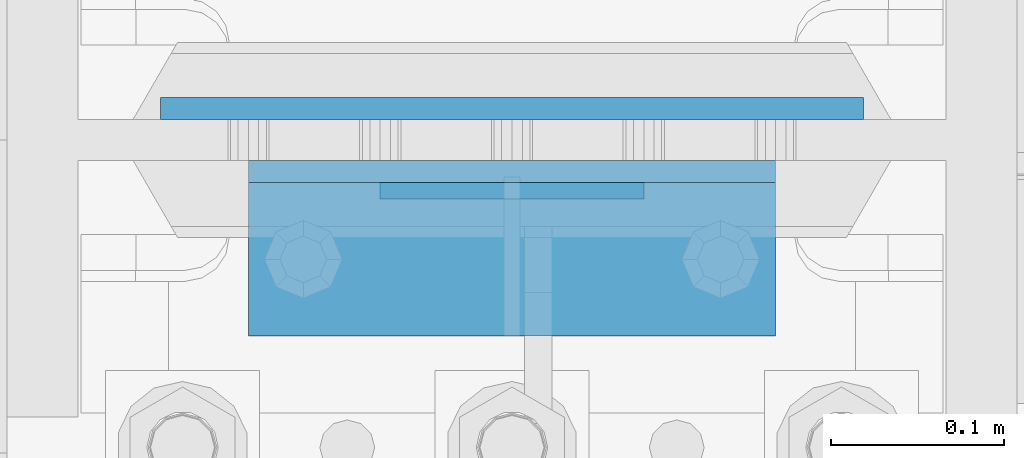
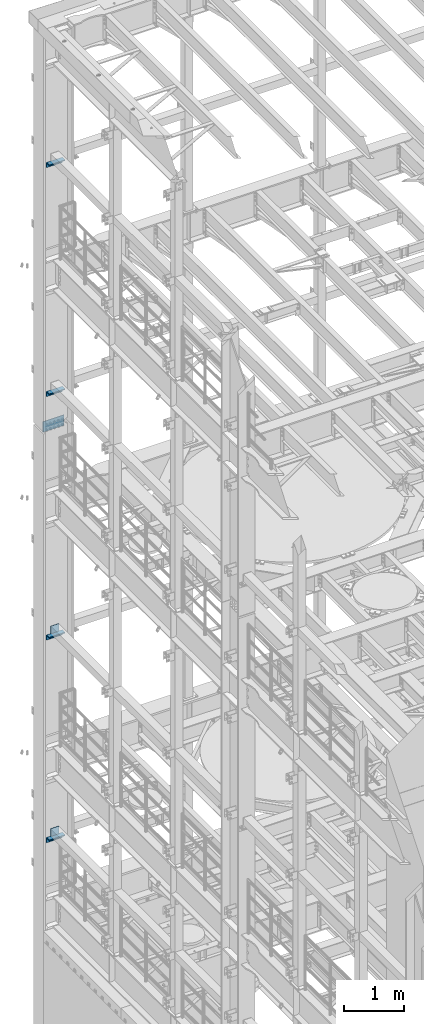
# One storey, part 1317 of 1876: 11 beams, 6 elements without a shape of their own.
"""IFC2X3 building model written with IfcOpenShell, lengths in millimetres."""

from ifc_helpers import new_model, si_unit, frame, origin_with_axes, place, context, subcontext, project, spatial, faceted_brep, material, type_object, element, aggregate, save


model = new_model("IFC2X3")

# Units and contexts
model_context = context("Model", 3, precision=1e-05, world=origin_with_axes())
body_context = subcontext(model_context, "Body", "Model", "MODEL_VIEW")
ifc_project = project(units=[si_unit("LENGTHUNIT", "METRE", prefix="MILLI"), si_unit("AREAUNIT", "SQUARE_METRE"), si_unit("VOLUMEUNIT", "CUBIC_METRE"), si_unit("MASSUNIT", "GRAM", prefix="KILO"), si_unit("TIMEUNIT", "SECOND"), si_unit("PLANEANGLEUNIT", "RADIAN"), si_unit("SOLIDANGLEUNIT", "STERADIAN"), si_unit("THERMODYNAMICTEMPERATUREUNIT", "DEGREE_CELSIUS"), si_unit("LUMINOUSINTENSITYUNIT", "LUMEN")], contexts=[model_context])

# Site, building, storey
site_placement = place(None, origin_with_axes())
site = spatial("IfcSite", under=ifc_project, at=site_placement, CompositionType="ELEMENT")
building_placement = place(site_placement, origin_with_axes())
building = spatial("IfcBuilding", under=site, at=building_placement, Name="Undefined", CompositionType="ELEMENT")
storey_placement = place(building_placement, origin_with_axes())
storey = spatial("IfcBuildingStorey", under=building, at=storey_placement, Name="Undefined", CompositionType="ELEMENT", Elevation=0.0)

# Assembly, beam
assembly_1_placement = place(storey_placement, origin_with_axes())
assembly_1 = element("IfcElementAssembly", 1, at=assembly_1_placement, inside=storey, Name="BEAM", AssemblyPlace="NOTDEFINED", PredefinedType="RIGID_FRAME")
ifc_material_1 = material(Name="STEEL/A36")
beam_type_1 = type_object("IfcBeamType", PredefinedType="NOTDEFINED")
beam_1_placement = place(assembly_1_placement, frame((76.1999999999998, 13686.63125, 10420.35), z_axis=(0.0, 0.0, -1.0), x_axis=(-1.0, 0.0, 0.0)))
beam_1 = element("IfcBeam", 2, at=beam_1_placement, type_object=beam_type_1, material=ifc_material_1, Name="PLATE", context=body_context, shape_type="Brep", body=[
    faceted_brep([(0.0, 4.76249999999982, -76.1999999999998), (3.63797880709171e-12, 4.76249999999982, 76.1999969482422), (152.399993896484, 4.76250000000073, 76.1999969482422), (152.4, 4.76249999999982, -76.1999999999998), (3.63797880709171e-12, -4.76249999999982, 76.1999969482422), (152.399993896484, -4.76250000000073, 76.1999969482422), (0.0, -4.76249999999982, -76.1999999999998), (152.4, -4.76249999999982, -76.1999999999998)], [[[0, 1, 2, 3]], [[4, 5, 2, 1]], [[4, 6, 7, 5]], [[6, 0, 3, 7]], [[5, 7, 3, 2]], [[6, 4, 1, 0]]]),
])

assembly_2_placement = place(storey_placement, origin_with_axes())
assembly_2 = element("IfcElementAssembly", 3, at=assembly_2_placement, inside=storey, Name="BEAM", AssemblyPlace="NOTDEFINED", PredefinedType="RIGID_FRAME")
beam_2_placement = place(assembly_2_placement, frame((76.1999999999998, 13686.63125, 6330.95), z_axis=(0.0, 0.0, -1.0), x_axis=(-1.0, 0.0, 0.0)))
beam_2 = element("IfcBeam", 4, at=beam_2_placement, type_object=beam_type_1, material=ifc_material_1, Name="PLATE", context=body_context, shape_type="Brep", body=[
    faceted_brep([(0.0, 4.76249999999982, -76.1999999999998), (3.63797880709171e-12, 4.76249999999982, 76.1999969482422), (152.399993896484, 4.76250000000073, 76.1999969482422), (152.4, 4.76249999999982, -76.1999999999998), (3.63797880709171e-12, -4.76249999999982, 76.1999969482422), (152.399993896484, -4.76250000000073, 76.1999969482422), (0.0, -4.76249999999982, -76.1999999999998), (152.4, -4.76249999999982, -76.1999999999998)], [[[0, 1, 2, 3]], [[4, 5, 2, 1]], [[4, 6, 7, 5]], [[6, 0, 3, 7]], [[5, 7, 3, 2]], [[6, 4, 1, 0]]]),
])

assembly_3_placement = place(storey_placement, origin_with_axes())
assembly_3 = element("IfcElementAssembly", 5, at=assembly_3_placement, inside=storey, Name="BEAM", AssemblyPlace="NOTDEFINED", PredefinedType="RIGID_FRAME")
beam_type_2 = type_object("IfcBeamType", PredefinedType="NOTDEFINED")
beam_3_placement = place(assembly_3_placement, frame((-152.400000000001, 13646.94375, 19877.0875), z_axis=(0.0, -1.0, 0.0), x_axis=(1.0, 0.0, 0.0)))
beam_3 = element("IfcBeam", 6, at=beam_3_placement, type_object=beam_type_2, material=ifc_material_1, Name="PLATE", context=body_context, shape_type="Brep", body=[
    faceted_brep([(0.0, 4.76250000000073, -44.4499999999998), (0.0, 4.76250000000073, 44.4499999999998), (304.799999999999, 4.76250000000073, 44.4499999999998), (304.799999999999, 4.76250000000073, -44.4499999999998), (0.0, -4.76250000000073, 44.4499999999998), (304.799999999999, -4.76250000000073, 44.4499999999998), (0.0, -4.76250000000073, -44.4499999999998), (304.799999999999, -4.76250000000073, -44.4499999999998)], [[[0, 1, 2, 3]], [[1, 4, 5, 2]], [[4, 6, 7, 5]], [[6, 0, 3, 7]], [[5, 7, 3, 2]], [[6, 4, 1, 0]]]),
])
aggregate(assembly_3, [beam_3])

assembly_4_placement = place(storey_placement, origin_with_axes())
assembly_4 = element("IfcElementAssembly", 7, at=assembly_4_placement, inside=storey, Name="BEAM", AssemblyPlace="NOTDEFINED", PredefinedType="RIGID_FRAME")
beam_4_placement = place(assembly_4_placement, frame((-152.400000000001, 13646.94375, 15254.2875), z_axis=(0.0, -1.0, 0.0), x_axis=(1.0, 0.0, 0.0)))
beam_4 = element("IfcBeam", 8, at=beam_4_placement, type_object=beam_type_2, material=ifc_material_1, Name="PLATE", context=body_context, shape_type="Brep", body=[
    faceted_brep([(0.0, 4.76250000000073, -44.4499999999998), (0.0, 4.76250000000073, 44.4499999999998), (304.799999999999, 4.76250000000073, 44.4499999999998), (304.799999999999, 4.76250000000073, -44.4499999999998), (0.0, -4.76250000000073, 44.4499999999998), (304.799999999999, -4.76250000000073, 44.4499999999998), (0.0, -4.76250000000073, -44.4499999999998), (304.799999999999, -4.76250000000073, -44.4499999999998)], [[[0, 1, 2, 3]], [[1, 4, 5, 2]], [[4, 6, 7, 5]], [[6, 0, 3, 7]], [[5, 7, 3, 2]], [[6, 4, 1, 0]]]),
])
aggregate(assembly_4, [beam_4])

# Beam
beam_5_placement = place(assembly_1_placement, frame((-152.400000000001, 13646.94375, 10339.3875), z_axis=(0.0, -1.0, 0.0), x_axis=(1.0, 0.0, 0.0)))
beam_5 = element("IfcBeam", 9, at=beam_5_placement, type_object=beam_type_2, material=ifc_material_1, Name="PLATE", context=body_context, shape_type="Brep", body=[
    faceted_brep([(0.0, 4.76250000000073, -44.4499999999998), (0.0, 4.76250000000073, 44.4499999999998), (304.799999999999, 4.76250000000073, 44.4499999999998), (304.799999999999, 4.76250000000073, -44.4499999999998), (0.0, -4.76250000000073, 44.4499999999998), (304.799999999999, -4.76250000000073, 44.4499999999998), (0.0, -4.76250000000073, -44.4499999999998), (304.799999999999, -4.76250000000073, -44.4499999999998)], [[[0, 1, 2, 3]], [[1, 4, 5, 2]], [[4, 6, 7, 5]], [[6, 0, 3, 7]], [[5, 7, 3, 2]], [[6, 4, 1, 0]]]),
])

aggregate(assembly_1, [beam_1, beam_5])

beam_6_placement = place(assembly_2_placement, frame((-152.400000000001, 13646.94375, 6249.9875), z_axis=(0.0, -1.0, 0.0), x_axis=(1.0, 0.0, 0.0)))
beam_6 = element("IfcBeam", 10, at=beam_6_placement, type_object=beam_type_2, material=ifc_material_1, Name="PLATE", context=body_context, shape_type="Brep", body=[
    faceted_brep([(0.0, 4.76250000000073, -44.4499999999998), (0.0, 4.76250000000073, 44.4499999999998), (304.799999999999, 4.76250000000073, 44.4499999999998), (304.799999999999, 4.76250000000073, -44.4499999999998), (0.0, -4.76250000000073, 44.4499999999998), (304.799999999999, -4.76250000000073, 44.4499999999998), (0.0, -4.76250000000073, -44.4499999999998), (304.799999999999, -4.76250000000073, -44.4499999999998)], [[[0, 1, 2, 3]], [[1, 4, 5, 2]], [[4, 6, 7, 5]], [[6, 0, 3, 7]], [[5, 7, 3, 2]], [[6, 4, 1, 0]]]),
])

aggregate(assembly_2, [beam_2, beam_6])

# Assembly, beams
assembly_5_placement = place(storey_placement, origin_with_axes())
assembly_5 = element("IfcElementAssembly", 11, at=assembly_5_placement, inside=storey, Name="COLUMN", AssemblyPlace="NOTDEFINED", PredefinedType="RIGID_FRAME")
beam_type_3 = type_object("IfcBeamType", Name="L4X4X3/8", PredefinedType="NOTDEFINED")
beam_7_placement = place(assembly_5_placement, frame((-152.400000000001, 13653.29375, 19821.525), z_axis=(0.0, -1.0, 0.0), x_axis=(1.0, 0.0, 0.0)))
beam_7 = element("IfcBeam", 12, at=beam_7_placement, type_object=beam_type_3, material=ifc_material_1, Name="ANGLE", ObjectType="L4X4X3/8", context=body_context, shape_type="Brep", body=[
    faceted_brep([(0.0, 50.7999999999993, -50.8000000000002), (0.0, 50.7999999999993, 50.8000000000002), (304.799999999999, 50.7999999999993, 50.8000000000002), (304.799999999999, 50.7999999999993, -50.8000000000002), (0.0, 41.2750000000015, 50.8000000000002), (304.799999999999, 41.2750000000015, 50.8000000000002), (0.0, 41.2750000000015, -41.2749999999996), (304.799999999999, 41.2750000000015, -41.2749999999996), (0.0, -50.7999999999993, -41.2749999999996), (304.799999999999, -50.7999999999993, -41.2749999999996), (0.0, -50.7999999999993, -50.8000000000002), (304.799999999999, -50.7999999999993, -50.8000000000002)], [[[0, 1, 2, 3]], [[1, 4, 5, 2]], [[4, 6, 7, 5]], [[6, 8, 9, 7]], [[8, 10, 11, 9]], [[10, 0, 3, 11]], [[5, 7, 9, 11, 3, 2]], [[10, 8, 6, 4, 1, 0]]]),
])
beam_8_placement = place(assembly_5_placement, frame((-152.400000000001, 13653.29375, 15198.725), z_axis=(0.0, -1.0, 0.0), x_axis=(1.0, 0.0, 0.0)))
beam_8 = element("IfcBeam", 13, at=beam_8_placement, type_object=beam_type_3, material=ifc_material_1, Name="ANGLE", ObjectType="L4X4X3/8", context=body_context, shape_type="Brep", body=[
    faceted_brep([(0.0, 50.7999999999993, -50.8000000000002), (0.0, 50.7999999999993, 50.8000000000002), (304.799999999999, 50.7999999999993, 50.8000000000002), (304.799999999999, 50.7999999999993, -50.8000000000002), (0.0, 41.2750000000015, 50.8000000000002), (304.799999999999, 41.2750000000015, 50.8000000000002), (0.0, 41.2750000000015, -41.2749999999996), (304.799999999999, 41.2750000000015, -41.2749999999996), (0.0, -50.7999999999993, -41.2749999999996), (304.799999999999, -50.7999999999993, -41.2749999999996), (0.0, -50.7999999999993, -50.8000000000002), (304.799999999999, -50.7999999999993, -50.8000000000002)], [[[0, 1, 2, 3]], [[1, 4, 5, 2]], [[4, 6, 7, 5]], [[6, 8, 9, 7]], [[8, 10, 11, 9]], [[10, 0, 3, 11]], [[5, 7, 9, 11, 3, 2]], [[10, 8, 6, 4, 1, 0]]]),
])
aggregate(assembly_5, [beam_7, beam_8])

assembly_6_placement = place(storey_placement, origin_with_axes())
assembly_6 = element("IfcElementAssembly", 14, at=assembly_6_placement, inside=storey, Name="COLUMN", AssemblyPlace="NOTDEFINED", PredefinedType="RIGID_FRAME")
beam_9_placement = place(assembly_6_placement, frame((-152.400000000001, 13653.29375, 10283.825), z_axis=(0.0, -1.0, 0.0), x_axis=(1.0, 0.0, 0.0)))
beam_9 = element("IfcBeam", 15, at=beam_9_placement, type_object=beam_type_3, material=ifc_material_1, Name="ANGLE", ObjectType="L4X4X3/8", context=body_context, shape_type="Brep", body=[
    faceted_brep([(0.0, 50.7999999999993, -50.8000000000002), (0.0, 50.7999999999993, 50.8000000000002), (304.799999999999, 50.7999999999993, 50.8000000000002), (304.799999999999, 50.7999999999993, -50.8000000000002), (0.0, 41.2750000000015, 50.8000000000002), (304.799999999999, 41.2750000000015, 50.8000000000002), (0.0, 41.2750000000015, -41.2749999999996), (304.799999999999, 41.2750000000015, -41.2749999999996), (0.0, -50.7999999999993, -41.2749999999996), (304.799999999999, -50.7999999999993, -41.2749999999996), (0.0, -50.7999999999993, -50.8000000000002), (304.799999999999, -50.7999999999993, -50.8000000000002)], [[[0, 1, 2, 3]], [[1, 4, 5, 2]], [[4, 6, 7, 5]], [[6, 8, 9, 7]], [[8, 10, 11, 9]], [[10, 0, 3, 11]], [[5, 7, 9, 11, 3, 2]], [[10, 8, 6, 4, 1, 0]]]),
])
beam_10_placement = place(assembly_6_placement, frame((-152.400000000001, 13653.29375, 6194.425), z_axis=(0.0, -1.0, 0.0), x_axis=(1.0, 0.0, 0.0)))
beam_10 = element("IfcBeam", 16, at=beam_10_placement, type_object=beam_type_3, material=ifc_material_1, Name="ANGLE", ObjectType="L4X4X3/8", context=body_context, shape_type="Brep", body=[
    faceted_brep([(0.0, 50.7999999999993, -50.8000000000002), (0.0, 50.7999999999993, 50.8000000000002), (304.799999999999, 50.7999999999993, 50.8000000000002), (304.799999999999, 50.7999999999993, -50.8000000000002), (0.0, 41.2750000000015, 50.8000000000002), (304.799999999999, 41.2750000000015, 50.8000000000002), (0.0, 41.2750000000015, -41.2749999999996), (304.799999999999, 41.2750000000015, -41.2749999999996), (0.0, -50.7999999999993, -41.2749999999996), (304.799999999999, -50.7999999999993, -41.2749999999996), (0.0, -50.7999999999993, -50.8000000000002), (304.799999999999, -50.7999999999993, -50.8000000000002)], [[[0, 1, 2, 3]], [[1, 4, 5, 2]], [[4, 6, 7, 5]], [[6, 8, 9, 7]], [[8, 10, 11, 9]], [[10, 0, 3, 11]], [[5, 7, 9, 11, 3, 2]], [[10, 8, 6, 4, 1, 0]]]),
])
ifc_material_2 = material(Name="STEEL/A572-50")
beam_type_4 = type_object("IfcBeamType", PredefinedType="NOTDEFINED")
beam_11_placement = place(assembly_6_placement, frame((0.0, 13734.25625, 14636.75), z_axis=(-1.0, 0.0, 0.0), x_axis=(0.0, 0.0, -1.0)))
beam_11 = element("IfcBeam", 17, at=beam_11_placement, type_object=beam_type_4, material=ifc_material_2, Name="PLATE", context=body_context, shape_type="Brep", body=[
    faceted_brep([(0.0, 6.35000000000036, -203.2), (0.0, 6.35000000000036, 203.2), (209.550000000001, 6.35000000000036, 203.2), (209.550000000001, 6.35000000000036, -203.2), (0.0, -6.35000000000036, 203.2), (209.550000000001, -6.35000000000036, 203.2), (0.0, -6.35000000000036, -203.2), (209.550000000001, -6.35000000000036, -203.2)], [[[0, 1, 2, 3]], [[1, 4, 5, 2]], [[4, 6, 7, 5]], [[6, 0, 3, 7]], [[5, 7, 3, 2]], [[6, 4, 1, 0]]]),
])
aggregate(assembly_6, [beam_9, beam_10, beam_11])

save(model, "model.ifc")
